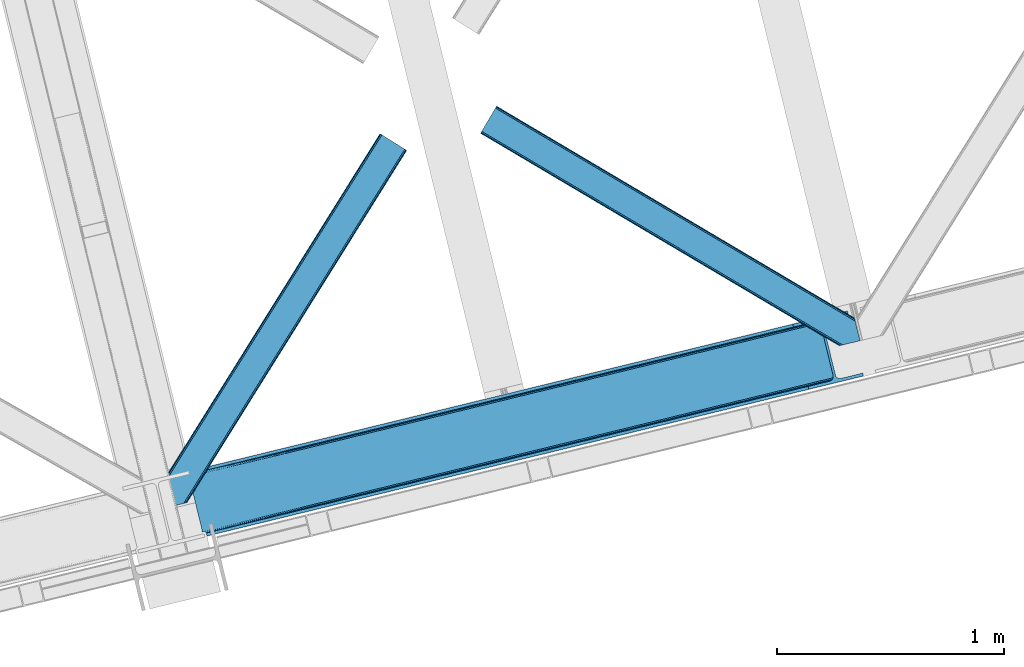
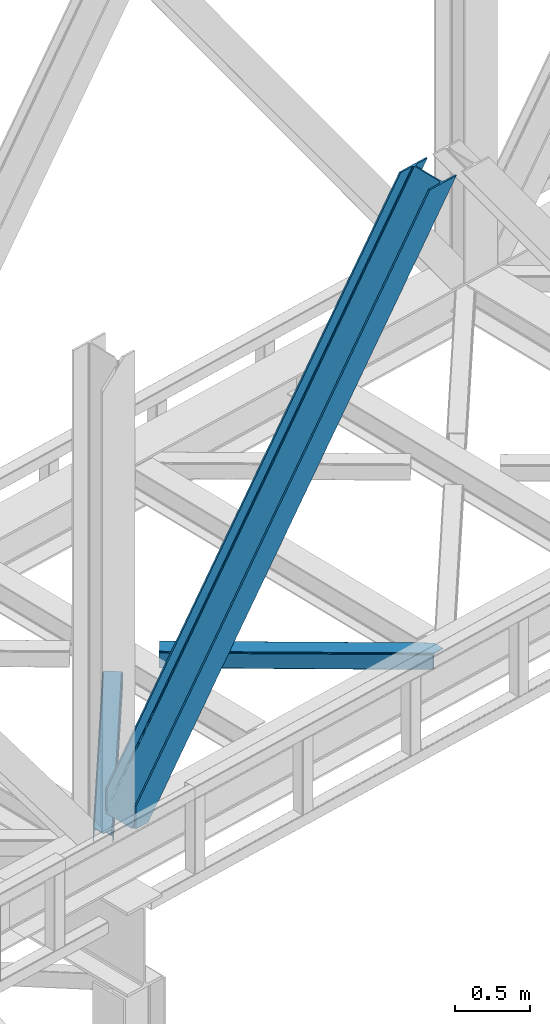
# One storey, part 57 of 93: 3 members.
"""IFC4 building model written with IfcOpenShell, lengths in millimetres."""

from ifc_helpers import new_model, entity, si_unit, converted_unit, derived_unit, direction, frame, origin, place, context, subcontext, project, spatial, triangles, type_object, element, save


model = new_model("IFC4")

# Units and contexts
model_context = context("Model", 3, precision=0.01, world=origin(), true_north=direction((6.12303176911189e-17, 1.0)))
plan_context = context("Plan", 3, precision=0.01, world=origin(), true_north=direction((6.12303176911189e-17, 1.0)))
body_context = subcontext(model_context, "Body", "Model", "MODEL_VIEW")
ifc_project = project(units=[si_unit("LENGTHUNIT", "METRE", prefix="MILLI"), si_unit("AREAUNIT", "SQUARE_METRE"), si_unit("VOLUMEUNIT", "CUBIC_METRE"), converted_unit("PLANEANGLEUNIT", "DEGREE", entity("IfcRatioMeasure", 0.0174532925199433), si_unit("PLANEANGLEUNIT", "RADIAN"), dimensions=[0, 0, 0, 0, 0, 0, 0]), si_unit("MASSUNIT", "GRAM", prefix="KILO"), derived_unit("MASSDENSITYUNIT", [(si_unit("MASSUNIT", "GRAM", prefix="KILO"), 1), (si_unit("LENGTHUNIT", "METRE"), -3)]), derived_unit("MOMENTOFINERTIAUNIT", [(si_unit("LENGTHUNIT", "METRE"), 4)]), si_unit("TIMEUNIT", "SECOND"), si_unit("FREQUENCYUNIT", "HERTZ"), si_unit("THERMODYNAMICTEMPERATUREUNIT", "DEGREE_CELSIUS"), derived_unit("THERMALTRANSMITTANCEUNIT", [(si_unit("MASSUNIT", "GRAM", prefix="KILO"), 1), (si_unit("THERMODYNAMICTEMPERATUREUNIT", "KELVIN"), -1), (si_unit("TIMEUNIT", "SECOND"), -3)]), derived_unit("VOLUMETRICFLOWRATEUNIT", [(si_unit("LENGTHUNIT", "METRE"), 3), (si_unit("TIMEUNIT", "SECOND"), -1)]), derived_unit("MASSFLOWRATEUNIT", [(si_unit("MASSUNIT", "GRAM", prefix="KILO"), 1), (si_unit("TIMEUNIT", "SECOND"), -1)]), derived_unit("ROTATIONALFREQUENCYUNIT", [(si_unit("TIMEUNIT", "SECOND"), -1)]), si_unit("ELECTRICCURRENTUNIT", "AMPERE"), si_unit("ELECTRICVOLTAGEUNIT", "VOLT"), si_unit("POWERUNIT", "WATT"), si_unit("FORCEUNIT", "NEWTON", prefix="KILO"), si_unit("ILLUMINANCEUNIT", "LUX"), si_unit("LUMINOUSFLUXUNIT", "LUMEN"), si_unit("LUMINOUSINTENSITYUNIT", "CANDELA"), derived_unit("USERDEFINED", [(si_unit("MASSUNIT", "GRAM", prefix="KILO"), -1), (si_unit("LENGTHUNIT", "METRE"), -2), (si_unit("TIMEUNIT", "SECOND"), 3), (si_unit("LUMINOUSFLUXUNIT", "LUMEN"), 1)]), derived_unit("LINEARVELOCITYUNIT", [(si_unit("LENGTHUNIT", "METRE"), 1), (si_unit("TIMEUNIT", "SECOND"), -1)]), si_unit("PRESSUREUNIT", "PASCAL"), derived_unit("USERDEFINED", [(si_unit("LENGTHUNIT", "METRE"), -2), (si_unit("MASSUNIT", "GRAM", prefix="KILO"), 1), (si_unit("TIMEUNIT", "SECOND"), -2)]), derived_unit("LINEARFORCEUNIT", [(si_unit("MASSUNIT", "GRAM", prefix="KILO"), 1), (si_unit("LENGTHUNIT", "METRE"), 1), (si_unit("TIMEUNIT", "SECOND"), -2), (si_unit("LENGTHUNIT", "METRE"), -1)]), derived_unit("PLANARFORCEUNIT", [(si_unit("MASSUNIT", "GRAM", prefix="KILO"), 1), (si_unit("LENGTHUNIT", "METRE"), 1), (si_unit("TIMEUNIT", "SECOND"), -2), (si_unit("LENGTHUNIT", "METRE"), -2)])], contexts=[model_context, plan_context])

# Site, building, storey
site_placement = place(None, origin())
site = spatial("IfcSite", under=ifc_project, at=site_placement, CompositionType="ELEMENT")
building_placement = place(site_placement, origin())
building = spatial("IfcBuilding", under=site, at=building_placement, CompositionType="ELEMENT")
storey_placement = place(building_placement, frame((0.0, 0.0, 15900.0)))
storey = spatial("IfcBuildingStorey", under=building, at=storey_placement, CompositionType="ELEMENT", Elevation=15900.0)

# Members
member_type_1 = type_object("IfcMemberType", PredefinedType="BRACE")
member_1_placement = place(storey_placement, frame((-29318.7080932617, 10322.5675964355, 3694.99929199219)))
element("IfcMember", 1, at=member_1_placement, inside=storey, type_object=member_type_1, ObjectType="Steel Vertical Brace", PredefinedType="BRACE", context=body_context, shape_type="Tessellation", body=[
    triangles([(58.549914550782, 26.6251190185558, 0.0), (60.4428222656279, 18.8523376464855, 0.0), (59.105694580081, 19.6708923339847, 0.80925292968459), (58.9708190917991, 18.4930572509766, 1.10690917968532), (64.0867858886741, 19.7406555175785, 8.31577148437282), (64.0867858886741, 19.7406555175785, 0.0), (522.907617187502, 126.716683959961, 658.855133056641), (68.3748962402351, 19.9243652343757, 14.8293273925774), (72.407208251956, 18.4523620605469, 22.4381652832017), (524.584259033203, 133.136059570314, 656.552947998047), (73.9861816406265, 17.2873168945316, 26.4425720214822), (2834.75720214844, 696.264477539064, 3911.00081176758), (2834.77580566406, 703.359393310548, 3911.00081176758), (2385.95203857422, 593.954443359375, 3278.7231262207), (2386.50781860352, 586.999053955078, 3279.53005371094), (2831.44577636719, 689.447451782227, 3911.00081176758), (2384.82885131836, 580.579678344728, 3281.83223876953), (2825.34149780274, 683.943136596679, 3911.00081176758), (2381.1709350586, 575.671838378907, 3285.27854003906), (2817.37686767578, 680.591015625001, 3911.00081176758), (2376.09450073242, 573.024325561524, 3289.34108276367), (514.170941162112, 119.160168457032, 666.36397705078), (519.249700927736, 121.80884399414, 662.301434326171), (77.0999450683594, 12.6201599121105, 50.6410949707024), (76.5674194335952, 13.9003143310547, 38.6743835449197), (75.4046997070327, 15.4258026123043, 33.1630920410134), (524.028479003908, 140.090286254883, 655.74602050781), (990.065148925783, 246.602389526368, 1312.29896850586), (989.509368896484, 253.556616210937, 1311.48971557617), (1455.54603881836, 360.067556762695, 1968.04266357422), (1454.99025878906, 367.021783447266, 1967.23341064453), (1921.02692871094, 473.533886718751, 2623.78635864258), (1920.47114868164, 480.48811340332, 2622.97710571289), (988.388507080079, 240.18185119629, 1314.598828125), (1453.8670715332, 353.648181152344, 1970.34484863281), (1919.34796142578, 467.113348388672, 2626.08854370117), (984.730590820313, 235.274011230469, 1318.04512939453), (1450.21148071289, 348.740341186523, 1973.78882446289), (1915.69004516602, 462.205508422852, 2629.53251953125), (979.651831054689, 232.626498413087, 1322.10767211914), (1445.13272094727, 346.092828369141, 1977.85369262695), (1910.61361083985, 459.55799560547, 2633.59738769531), (77.0999450683594, 12.6201599121105, 182.433050537107), (2723.82443847656, 657.78659362793, 3911.00081176758), (75.569805908206, 15.550213623048, 0.0), (77.381323242189, 11.6585906982418, 0.0), (77.381323242189, 11.6585906982418, 182.495837402341), (68.3748962402351, 19.9243652343757, 0.0), (72.407208251956, 18.4523620605469, 0.0), (2726.9033203125, 645.157131958009, 3911.00081176758), (80.223010253907, 0.0, 182.495837402341), (80.223010253907, 0.0, 0.0), (191.327856445314, 27.0832305908207, 0.0), (2967.5537475586, 703.817504882813, 3911.00081176758), (1399.80990600586, 593.394012451172, 1967.23341064453), (2779.59312744141, 929.730459594726, 3911.00081176758), (2330.77168579102, 820.325509643555, 3278.7231262207), (1865.29079589844, 706.859179687501, 2622.97710571289), (934.329016113283, 479.927682495118, 1311.48971557617), (468.848126220706, 366.462515258789, 655.74602050781), (3.36723632812573, 252.996185302734, 0.0), (2964.47486572266, 716.448129272461, 3911.00081176758), (188.248974609378, 39.7138549804695, 0.0), (2870.92243652344, 693.643707275391, 3911.00081176758), (94.6965454101592, 16.9094329833988, 0.0), (2862.31133422852, 692.954214477539, 3911.00081176758), (86.083117675782, 16.2199401855469, 0.0), (2854.35833129883, 695.031994628907, 3911.00081176758), (78.1324401855491, 18.2977203369137, 0.0), (2848.28195800781, 699.561950683594, 3911.00081176758), (72.0560668945327, 22.8265136718746, 0.0), (2845.00308837891, 705.852264404297, 3911.00081176758), (68.7748718261719, 29.1168273925778, 0.0), (2789.82273559571, 932.224493408203, 3911.00081176758), (13.5945190429702, 255.489056396485, 0.0), (2789.83668823242, 939.318246459961, 3911.00081176758), (13.6107971191414, 262.583972167969, 0.0), (2793.15043945313, 946.135272216798, 3911.00081176758), (16.9245483398445, 269.400997924806, 0.0), (2799.25471801758, 951.639587402344, 3911.00081176758), (23.026501464843, 274.905313110352, 0.0), (2807.21702270508, 954.991708374024, 3911.00081176758), (30.9911315917961, 278.256271362305, 0.0), (2900.7694519043, 977.796130371094, 3911.00081176758), (124.543560791019, 301.060693359375, 0.0), (2897.69057006836, 990.425592041016, 3911.00081176758), (121.464678955079, 313.691317749024, 0.0), (2770.23555908203, 940.550729370118, 3911.00081176758), (2762.2848815918, 942.628509521484, 3911.00081176758), (2657.04014282227, 931.765219116211, 3911.00081176758), (2753.67145385742, 941.939016723632, 3911.00081176758), (2660.1190246582, 919.134594726564, 3911.00081176758), (2776.3142578125, 936.020773315429, 3911.00081176758), (10.3598327636719, 286.608087158203, 182.495837402341), (10.3598327636719, 286.608087158203, 0.0), (13.2015197753899, 274.949496459962, 182.495837402341), (13.3922058105491, 273.966998291016, 182.433050537107), (1381.42730712891, 607.439666748047, 1977.85369262695), (1846.90819702149, 720.905996704101, 2633.59738769531), (2312.38676147461, 834.37116394043, 3289.34108276367), (915.94641723633, 493.97449951172, 1322.10767211914), (13.3922058105491, 273.966998291016, 50.6410949707024), (450.465527343753, 380.508169555664, 666.36397705078), (13.2015197753899, 274.949496459962, 0.0), (13.5108032226563, 272.58568725586, 38.6743835449197), (13.3829040527344, 270.661386108399, 0.0), (13.3829040527344, 270.661386108399, 32.1678039550752), (12.4783081054702, 268.183630371093, 26.1867736816384), (11.9132263183601, 266.62907409668, 22.4381652832017), (11.9132263183601, 266.62907409668, 0.0), (9.00875244140843, 263.467639160157, 14.8293273925774), (9.00875244140843, 263.467639160157, 0.0), (5.11829223632958, 261.6572845459, 8.31577148437282), (5.11829223632958, 261.6572845459, 0.0), (1.47432861328343, 260.768966674805, 0.0), (461.697399902347, 377.819961547852, 658.855133056641), (456.193084716797, 380.494216918945, 662.301434326171), (466.141314697266, 372.892355346679, 656.552947998047), (0.662750244140625, 259.427188110352, 0.80925292968459), (0.0, 260.409686279298, 1.10690917968532), (2318.11431884766, 834.357211303712, 3285.27854003906), (2323.62095947266, 831.682955932618, 3281.83223876953), (2328.06487426758, 826.755349731446, 3279.53005371094), (921.671649169923, 493.959384155274, 1318.04512939453), (1387.1525390625, 607.425714111328, 1973.78882446289), (1852.63342895508, 720.890881347657, 2629.53251953125), (927.178289794923, 491.28512878418, 1314.598828125), (1392.6591796875, 604.751458740235, 1970.34484863281), (1858.14006958008, 718.216625976564, 2626.08854370117), (931.622204589847, 486.358685302735, 1312.29896850586), (1397.10309448242, 599.823852539063, 1968.04266357422), (1862.583984375, 713.290182495117, 2623.78635864258)], [[1, 2, 3], [4, 3, 2], [5, 4, 6], [2, 6, 4], [7, 8, 9], [10, 3, 8], [8, 7, 10], [9, 11, 7], [3, 4, 5], [5, 8, 3], [12, 13, 14], [14, 15, 12], [16, 12, 15], [15, 17, 16], [18, 16, 17], [17, 19, 18], [20, 18, 19], [19, 21, 20], [22, 23, 24], [25, 24, 23], [25, 7, 26], [25, 23, 7], [11, 26, 7], [10, 27, 1], [1, 3, 10], [28, 29, 27], [27, 10, 28], [30, 31, 28], [29, 28, 31], [32, 33, 31], [31, 30, 32], [15, 14, 33], [33, 32, 15], [34, 28, 10], [10, 7, 34], [35, 30, 28], [28, 34, 35], [36, 32, 35], [30, 35, 32], [17, 15, 36], [32, 36, 15], [37, 34, 23], [7, 23, 34], [38, 35, 37], [34, 37, 35], [39, 36, 38], [35, 38, 36], [19, 17, 36], [36, 39, 19], [40, 37, 22], [23, 22, 37], [41, 38, 40], [37, 40, 38], [42, 39, 41], [38, 41, 39], [21, 19, 42], [39, 42, 19], [41, 43, 44], [44, 21, 42], [21, 44, 20], [42, 41, 44], [43, 41, 40], [40, 22, 43], [24, 43, 22], [45, 11, 9], [45, 26, 11], [46, 25, 26], [46, 47, 24], [43, 24, 47], [24, 25, 46], [26, 45, 46], [48, 8, 5], [5, 6, 48], [49, 9, 8], [8, 48, 49], [9, 49, 45], [47, 44, 43], [50, 47, 51], [47, 50, 44], [52, 51, 46], [47, 46, 51], [50, 53, 54], [53, 50, 51], [52, 53, 51], [33, 55, 31], [13, 56, 57], [58, 14, 57], [55, 33, 58], [57, 14, 13], [58, 33, 14], [31, 59, 29], [59, 60, 27], [59, 31, 55], [61, 1, 60], [59, 27, 29], [60, 1, 27], [62, 54, 53], [53, 63, 62], [64, 62, 63], [63, 65, 64], [66, 64, 65], [65, 67, 66], [68, 66, 67], [67, 69, 68], [70, 68, 69], [69, 71, 70], [72, 70, 71], [71, 73, 72], [74, 72, 75], [73, 75, 72], [76, 74, 77], [75, 77, 74], [78, 76, 79], [77, 79, 76], [80, 78, 81], [79, 81, 78], [82, 80, 83], [81, 83, 80], [84, 82, 85], [83, 85, 82], [86, 84, 85], [85, 87, 86], [56, 13, 74], [16, 18, 66], [20, 50, 54], [44, 50, 20], [18, 20, 64], [13, 12, 70], [12, 16, 68], [88, 80, 89], [90, 91, 86], [91, 89, 82], [90, 92, 91], [88, 93, 78], [93, 56, 76], [74, 13, 72], [64, 66, 18], [70, 12, 68], [66, 68, 16], [70, 72, 13], [54, 64, 20], [54, 62, 64], [82, 89, 80], [78, 93, 76], [74, 76, 56], [78, 80, 88], [82, 86, 91], [86, 82, 84], [90, 87, 94], [90, 86, 87], [87, 95, 94], [96, 90, 94], [92, 96, 97], [96, 92, 90], [92, 97, 98], [98, 99, 92], [99, 100, 92], [91, 92, 100], [101, 98, 97], [97, 102, 103], [103, 101, 97], [104, 96, 94], [94, 95, 104], [104, 105, 102], [104, 106, 107], [107, 105, 104], [96, 104, 102], [102, 97, 96], [108, 106, 109], [108, 107, 106], [110, 109, 106], [109, 110, 111], [112, 111, 110], [111, 112, 113], [114, 113, 112], [75, 73, 61], [114, 75, 61], [114, 112, 75], [114, 61, 115], [79, 77, 110], [77, 75, 112], [106, 79, 110], [110, 77, 112], [73, 1, 61], [6, 73, 48], [1, 6, 2], [1, 73, 6], [48, 71, 49], [49, 71, 69], [73, 71, 48], [45, 49, 69], [104, 81, 79], [79, 106, 104], [95, 81, 104], [83, 95, 87], [87, 85, 83], [83, 81, 95], [45, 69, 46], [52, 67, 65], [46, 69, 67], [52, 46, 67], [65, 53, 52], [53, 65, 63], [116, 117, 105], [105, 107, 116], [118, 111, 113], [113, 119, 118], [118, 116, 108], [108, 109, 118], [109, 111, 118], [113, 120, 119], [107, 108, 116], [117, 103, 102], [102, 105, 117], [89, 91, 121], [100, 121, 91], [88, 89, 122], [121, 122, 89], [93, 88, 123], [122, 123, 88], [56, 93, 57], [123, 57, 93], [124, 101, 103], [103, 117, 124], [125, 98, 101], [101, 124, 125], [126, 99, 98], [98, 125, 126], [121, 100, 126], [99, 126, 100], [127, 124, 116], [117, 116, 124], [128, 125, 124], [124, 127, 128], [129, 126, 128], [125, 128, 126], [122, 121, 129], [126, 129, 121], [130, 127, 118], [116, 118, 127], [131, 128, 130], [127, 130, 128], [132, 129, 128], [128, 131, 132], [123, 122, 129], [129, 132, 123], [60, 118, 61], [119, 61, 118], [59, 130, 60], [118, 60, 130], [55, 131, 130], [130, 59, 55], [58, 132, 55], [131, 55, 132], [57, 123, 58], [132, 58, 123], [120, 113, 114], [114, 115, 120], [115, 61, 119], [119, 120, 115]]),
])
member_type_2 = type_object("IfcMemberType", PredefinedType="BRACE")
member_2_placement = place(storey_placement, frame((-29442.5330932617, 10446.8344299316, 3510.00011901855)))
element("IfcMember", 2, at=member_2_placement, inside=storey, type_object=member_type_2, ObjectType="Steel Horizontal Brace", PredefinedType="BRACE", context=body_context, shape_type="Tessellation", body=[
    triangles([(116.813800048829, 229.38483581543, 5.52059326172093), (80.4834594726563, 220.529562377929, 5.52059326172093), (108.163165283204, 264.867553710938, 5.52059326172093), (117.183544921878, 229.4755279541, 5.44385375976708), (117.499804687501, 229.552267456054, 5.22758789062573), (108.467797851565, 265.047775268555, 5.35316162109666), (108.779406738282, 265.232647705077, 5.18107910156323), (109.021252441409, 265.045449829102, 4.88574829101708), (108.879400634767, 265.291946411133, 5.12526855468968), (117.709094238282, 229.603427124022, 4.90318908691552), (109.242169189456, 264.669891357422, 4.52065429687718), (117.783508300781, 229.622030639648, 4.52065429687718), (113.127978515626, 248.727841186523, 0.0), (110.909509277346, 257.823797607422, 1.33247680664135), (117.783508300781, 229.622030639648, 0.0), (973.808001708985, 1640.09989013672, 1.33247680664135), (968.992016601565, 1643.10668334961, 5.12526855468968), (965.773608398438, 1645.11586303711, 10.8028289794929), (75.7418884277358, 219.37265625, 10.8028289794929), (979.48905029297, 1636.5535949707, 0.0), (964.645770263673, 1645.82047119141, 17.5000946044929), (73.8885131835959, 218.921520996093, 17.5000946044929), (127.499194335938, 231.98932800293, 0.0), (1068.55803222656, 1580.95117492676, 0.0), (155.288195800782, 117.985821533202, 0.0), (1074.23908081055, 1577.40487976074, 1.33247680664135), (157.506665039065, 108.891027832031, 1.33247680664135), (1079.05506591797, 1574.39808654785, 5.12526855468968), (159.385620117188, 101.179870605469, 5.12526855468968), (1082.2734741211, 1572.39006958008, 10.8028289794929), (160.641357421875, 96.0278594970696, 10.8028289794929), (1083.40363769532, 1571.68429870605, 17.5000946044929), (161.083190917969, 94.2186676025394, 17.5000946044929), (127.499194335938, 231.98932800293, 6.99957275390625), (107.953875732423, 227.225665283202, 6.99957275390625), (98.6428161621116, 224.956036376952, 8.3320495605476), (86.1482299804702, 221.909710693359, 18.0686645507813), (90.7502746582031, 223.031735229491, 12.1260040283232), (84.264624023439, 221.450436401366, 20.4999114990242), (73.8885131835959, 218.921520996093, 20.4999114990242), (985.425897216799, 1632.84684448242, 6.99957275390625), (1062.62118530274, 1584.65792541504, 6.99957275390625), (152.972058105472, 127.492218017578, 6.99957275390625), (157.067156982423, 110.68742980957, 12.1260040283232), (155.188201904297, 118.397424316407, 8.3320495605476), (158.222900390625, 105.947021484375, 17.9802978515654), (158.52288208008, 104.716864013672, 19.4999725341804), (161.083190917969, 94.2186676025394, 19.4999725341804), (157.871759033205, 103.169284057616, 20.4999114990242), (160.341375732423, 93.0338562011711, 20.4999114990242), (116.220812988282, 22.3544494628895, 20.4999114990242), (105.842376708984, 19.8255340576161, 20.4999114990242), (1083.40363769532, 1571.68429870605, 122.500662231447), (116.220812988282, 22.3544494628895, 122.500662231447), (1076.33662719727, 1576.09682006836, 17.8035644531265), (1073.11821899414, 1578.10483703613, 12.1260040283232), (1077.46446533203, 1575.39104919434, 24.4996673583992), (106.486523437503, 19.982501220702, 24.4996673583992), (1068.30223388672, 1581.11163024902, 8.3320495605476), (1082.2734741211, 1572.39006958008, 129.197927856447), (114.367437744142, 21.9033142089847, 129.197927856447), (1079.05506591797, 1574.39808654785, 134.874325561526), (109.093341064454, 20.6173461914059, 134.874325561526), (1074.23908081055, 1577.40487976074, 138.667117309571), (101.198474121094, 18.6930450439449, 138.667117309571), (1068.55803222656, 1580.95117492676, 139.999594116212), (91.8874145507834, 16.4234161376953, 139.999594116212), (1077.46446533203, 1575.39104919434, 115.501089477541), (106.486523437503, 19.982501220702, 115.501089477541), (1062.62118530274, 1584.65792541504, 133.000021362306), (1068.30223388672, 1581.11163024902, 131.667544555665), (91.4641845703154, 16.3199340820302, 131.667544555665), (82.1554504394553, 14.0503051757805, 133.000021362306), (1073.11821899414, 1578.10483703613, 127.87475280762), (99.3613769531257, 18.2453979492184, 127.87475280762), (1076.33662719727, 1576.09682006836, 122.196029663086), (104.635473632814, 19.5302032470699, 122.196029663086), (24.5101318359375, 0.0, 139.999594116212), (24.5101318359375, 0.0, 133.000021362306), (2.46961669922166, 90.4212249755856, 20.4999114990242), (0.0, 100.556652832031, 20.4999114990242), (964.645770263673, 1645.82047119141, 122.500662231447), (0.0, 100.556652832031, 122.500662231447), (5.79266967773583, 76.7894989013676, 139.999594116212), (979.48905029297, 1636.5535949707, 139.999594116212), (973.808001708985, 1640.09989013672, 138.667117309571), (3.57652587890698, 85.8854553222645, 138.667117309571), (968.992016601565, 1643.10668334961, 134.874325561526), (1.69524536133031, 93.5954498291012, 134.874325561526), (965.773608398438, 1645.11586303711, 129.197927856447), (0.439508056642808, 98.7474609375004, 129.197927856447), (970.582617187501, 1642.11372070312, 24.4996673583992), (2.31613769531396, 91.0502563476566, 24.4996673583992), (971.710455322267, 1641.4079498291, 17.8035644531265), (979.744848632814, 1636.39313964844, 8.3320495605476), (974.928863525394, 1639.39993286133, 12.1260040283232), (974.928863525394, 1639.39993286133, 127.87475280762), (985.425897216799, 1632.84684448242, 133.000021362306), (979.744848632814, 1636.39313964844, 131.667544555665), (970.582617187501, 1642.11372070312, 115.501089477541), (971.710455322267, 1641.4079498291, 122.196029663086), (4.01370849609521, 84.0890533447255, 127.87475280762), (2.75797119140771, 89.2410644531246, 122.196029663086), (8.10880737304979, 67.2831024169918, 133.000021362306), (5.89266357422093, 76.3790588378906, 131.667544555665), (2.31613769531396, 91.0502563476566, 115.501089477541)], [[1, 2, 3], [4, 1, 3], [5, 4, 6], [5, 7, 8], [7, 9, 8], [10, 8, 11], [11, 12, 10], [8, 10, 5], [6, 7, 5], [3, 6, 4], [11, 13, 12], [13, 11, 14], [15, 12, 13], [16, 14, 11], [11, 17, 16], [11, 9, 17], [18, 17, 9], [18, 3, 19], [2, 19, 3], [16, 20, 14], [13, 14, 20], [21, 18, 19], [19, 22, 21], [23, 24, 25], [24, 13, 20], [13, 24, 23], [23, 15, 13], [24, 26, 25], [27, 25, 26], [26, 28, 27], [29, 27, 28], [28, 30, 29], [31, 29, 30], [30, 32, 31], [33, 31, 32], [15, 23, 10], [10, 34, 1], [34, 10, 23], [35, 1, 34], [36, 2, 35], [35, 2, 1], [2, 37, 19], [38, 37, 2], [2, 36, 38], [37, 39, 19], [39, 22, 19], [39, 40, 22], [34, 41, 35], [42, 34, 43], [34, 42, 41], [44, 27, 29], [34, 23, 43], [23, 25, 43], [27, 45, 25], [44, 45, 27], [45, 43, 25], [46, 44, 29], [31, 46, 29], [47, 31, 33], [31, 47, 46], [33, 48, 47], [49, 50, 51], [51, 52, 49], [53, 48, 32], [48, 53, 54], [33, 32, 48], [54, 50, 48], [54, 51, 50], [55, 56, 44], [57, 55, 46], [46, 47, 57], [47, 49, 57], [57, 49, 58], [52, 58, 49], [44, 46, 55], [56, 59, 45], [45, 44, 56], [59, 42, 43], [43, 45, 59], [53, 60, 54], [61, 54, 60], [60, 62, 61], [63, 61, 62], [62, 64, 63], [65, 63, 64], [64, 66, 65], [67, 65, 66], [68, 57, 69], [58, 69, 57], [70, 71, 72], [72, 73, 70], [71, 74, 75], [75, 72, 71], [74, 76, 77], [77, 75, 74], [76, 68, 69], [69, 77, 76], [77, 61, 63], [73, 67, 78], [78, 79, 73], [73, 72, 67], [72, 65, 67], [75, 65, 72], [63, 65, 75], [77, 54, 61], [69, 54, 77], [63, 75, 77], [51, 58, 52], [69, 51, 54], [58, 51, 69], [40, 39, 80], [80, 81, 40], [40, 21, 22], [82, 40, 83], [40, 82, 21], [40, 81, 83], [66, 84, 67], [66, 85, 84], [84, 78, 67], [85, 86, 87], [87, 84, 85], [86, 88, 89], [89, 87, 86], [88, 90, 91], [91, 89, 88], [90, 82, 83], [83, 91, 90], [92, 93, 39], [39, 94, 92], [39, 37, 94], [93, 80, 39], [94, 37, 38], [41, 95, 35], [36, 35, 95], [95, 96, 36], [38, 36, 96], [38, 96, 94], [30, 56, 55], [57, 53, 32], [30, 55, 32], [30, 28, 56], [55, 57, 32], [56, 28, 26], [42, 24, 20], [24, 59, 26], [59, 24, 42], [59, 56, 26], [60, 74, 62], [68, 53, 57], [53, 76, 60], [76, 53, 68], [60, 76, 74], [66, 70, 85], [64, 62, 74], [74, 71, 64], [71, 70, 66], [66, 64, 71], [96, 16, 17], [20, 41, 42], [20, 95, 41], [95, 20, 16], [96, 95, 16], [92, 21, 82], [18, 94, 96], [17, 18, 96], [94, 18, 21], [92, 94, 21], [86, 97, 88], [85, 70, 98], [98, 99, 85], [99, 97, 86], [86, 85, 99], [90, 88, 97], [82, 100, 92], [101, 82, 90], [82, 101, 100], [101, 90, 97], [102, 89, 103], [79, 78, 104], [78, 84, 104], [87, 105, 84], [102, 105, 87], [105, 104, 84], [102, 87, 89], [83, 81, 106], [91, 103, 89], [106, 103, 83], [103, 91, 83], [81, 93, 106], [81, 80, 93], [70, 104, 98], [104, 70, 73], [79, 104, 73], [92, 100, 93], [106, 93, 100], [100, 101, 106], [103, 106, 101], [101, 97, 103], [102, 103, 97], [97, 99, 102], [105, 102, 99], [99, 98, 105], [104, 105, 98]]),
])
member_type_3 = type_object("IfcMemberType", PredefinedType="BRACE")
member_3_placement = place(storey_placement, frame((-28035.698034668, 11159.1828094482, 3510.00011901855)))
element("IfcMember", 3, at=member_3_placement, inside=storey, type_object=member_type_3, ObjectType="Steel Horizontal Brace", PredefinedType="BRACE", context=body_context, shape_type="Tessellation", body=[
    triangles([(1465.49891967774, 208.966314697265, 0.0), (1500.25958862305, 66.3657165527347, 0.0), (8.91573486328343, 949.276940917969, 0.0), (62.405493164064, 1039.62956542969, 0.0), (0.679028320311772, 935.364999389649, 10.8028289794929), (1580.23377685547, 0.541827392578853, 10.8679412841811), (1578.00833129883, 0.0, 17.5000946044929), (1506.61734008789, 44.5019348144524, 9.52034912109593), (2.6114685058601, 938.628753662109, 5.12526855468968), (1504.3546875, 49.5597656249993, 5.12526855468968), (1505.23137817383, 45.9657989501957, 8.52041015625218), (1506.28247680664, 44.8554016113285, 9.27850341796875), (1505.92435913086, 45.2344482421868, 9.02037963867406), (1505.56624145508, 45.6123321533196, 8.76225585937573), (1580.68491210938, 0.65228576660229, 9.52034912109593), (1502.47573242188, 57.2709228515632, 1.33247680664135), (5.50431518554615, 943.514501953125, 1.33247680664135), (0.0, 934.218557739257, 17.5000946044929), (1578.00833129883, 0.0, 122.500662231447), (0.0, 934.218557739257, 122.500662231447), (1593.02834472656, 3.66140441894458, 138.667117309571), (1602.33940429688, 5.93103332519604, 139.999594116212), (8.91573486328343, 949.276940917969, 139.999594116212), (5.50431518554615, 943.514501953125, 138.667117309571), (1585.13347778321, 1.73710327148365, 134.874325561526), (2.6114685058601, 938.628753662109, 134.874325561526), (1579.85938110352, 0.451135253906614, 129.197927856447), (0.679028320311772, 935.364999389649, 129.197927856447), (1500.30377197266, 66.1831695556648, 8.52041015625218), (1500.66188964844, 65.0402160644535, 8.90294494629052), (1501.15255737305, 64.3216552734375, 9.10758361816625), (1501.64787597656, 63.5914672851559, 9.31571044922021), (1502.13854370117, 62.8729064941399, 9.52034912109593), (1599.49306640625, 5.23688964843677, 9.52034912109593), (9.07153930664208, 949.538552856446, 8.3320495605476), (1500.15029296875, 66.8075500488285, 8.42274169922166), (6.1786926269524, 944.65280456543, 12.1260040283232), (1594.86776733398, 4.11021423339844, 12.1260040283232), (1497.94112548828, 75.8721130371086, 6.99957275390625), (12.4829589843757, 955.300991821288, 6.99957275390625), (1589.5936706543, 2.82424621581958, 17.8035644531265), (4.24625244140771, 941.387887573243, 17.8035644531265), (1587.74029541016, 2.3719482421875, 24.4996673583992), (3.56489868164135, 940.241445922851, 24.4996673583992), (1467.81505737305, 199.458755493164, 6.99957275390625), (58.8405944824226, 1033.60667724609, 6.99957275390625), (1460.52713012695, 229.365069580079, 8.52041015625218), (1465.45473632813, 209.14769897461, 8.52041015625218), (1461.40149536133, 225.771102905273, 5.12526855468968), (1465.60588989258, 208.524481201172, 8.42274169922166), (1463.28045043946, 218.061108398437, 1.33247680664135), (1587.74029541016, 2.3719482421875, 115.501089477541), (3.56489868164135, 940.241445922851, 115.501089477541), (1589.5936706543, 2.82424621581958, 122.196029663086), (4.24625244140771, 941.387887573243, 122.196029663086), (1594.86776733398, 4.11021423339844, 127.87475280762), (6.1786926269524, 944.65280456543, 127.87475280762), (1602.76263427734, 6.03451538085938, 131.667544555665), (9.07153930664208, 949.538552856446, 131.667544555665), (1612.07369384766, 8.30414428710901, 133.000021362306), (12.4829589843757, 955.300991821288, 133.000021362306), (1669.50739746094, 22.3044525146488, 139.999594116212), (1669.50739746094, 22.3044525146488, 133.000021362306), (1650.74110107422, 99.2974273681648, 139.999594116212), (62.405493164064, 1039.62956542969, 139.999594116212), (1653.05723876953, 89.7910308837891, 133.000021362306), (58.8405944824226, 1033.60667724609, 133.000021362306), (1645.38793945313, 121.255389404298, 129.197927856447), (1644.94610595703, 123.064581298828, 122.500662231447), (70.642199707032, 1053.54266967773, 129.197927856447), (71.3235534667983, 1054.68911132813, 122.500662231447), (1646.64367675781, 116.103378295898, 134.874325561526), (68.7120849609382, 1050.27891540527, 134.874325561526), (1648.52263183594, 108.393383789062, 138.667117309571), (65.8192382812522, 1045.39316711426, 138.667117309571), (1644.94610595703, 123.064581298828, 17.5000946044929), (71.3235534667983, 1054.68911132813, 17.5000946044929), (70.642199707032, 1053.54266967773, 10.8028289794929), (65.1448608398459, 1044.25486450195, 12.1260040283232), (67.0773010253906, 1047.51978149414, 17.8035644531265), (67.7563293457024, 1048.6650604248, 24.4996673583992), (68.7120849609382, 1050.27891540527, 5.12526855468968), (65.8192382812522, 1045.39316711426, 1.33247680664135), (62.2520141601563, 1039.36911621094, 8.3320495605476), (65.1448608398459, 1044.25486450195, 127.87475280762), (67.7563293457024, 1048.6650604248, 115.501089477541), (67.0773010253906, 1047.51978149414, 122.196029663086), (62.2520141601563, 1039.36911621094, 131.667544555665), (1647.2645690918, 113.558184814454, 24.4996673583992), (1647.2645690918, 113.558184814454, 115.501089477541), (1650.8410949707, 98.8869873046879, 131.667544555665), (1648.96213989258, 106.596981811523, 127.87475280762), (1647.70640258789, 111.748992919922, 122.196029663086), (1647.79476928711, 111.385061645507, 17.8686767578147), (1647.90173950195, 110.943228149414, 16.5199218750022), (1644.95540771485, 123.027374267578, 16.5199218750022), (1638.66741943359, 124.97144165039, 10.8702667236357), (1460.74572143555, 229.701095581055, 9.22734375000073), (1460.63642578125, 229.532501220703, 8.87387695312646), (1461.54567260742, 229.405764770509, 9.52034912109593), (1637.16518554688, 125.43536682129, 9.52034912109593), (1643.67409057617, 109.725860595703, 12.1260040283232), (1466.02446899414, 211.034793090821, 9.52034912109593), (1641.64398193359, 107.063232421875, 9.52034912109593)], [[1, 2, 3], [3, 4, 1], [5, 6, 7], [6, 5, 8], [5, 9, 10], [10, 11, 5], [12, 5, 13], [12, 8, 5], [5, 14, 13], [5, 11, 14], [8, 15, 6], [16, 10, 9], [9, 17, 16], [2, 16, 17], [17, 3, 2], [7, 18, 5], [7, 19, 20], [20, 18, 7], [21, 22, 23], [23, 24, 21], [25, 21, 24], [24, 26, 25], [27, 25, 26], [26, 28, 27], [19, 27, 28], [28, 20, 19], [11, 29, 30], [14, 30, 31], [13, 31, 32], [12, 32, 33], [33, 8, 12], [32, 12, 13], [31, 13, 14], [30, 14, 11], [34, 15, 33], [8, 33, 15], [35, 30, 29], [32, 35, 33], [35, 32, 31], [30, 35, 31], [29, 36, 35], [37, 38, 33], [33, 35, 37], [38, 34, 33], [35, 36, 39], [39, 40, 35], [41, 38, 37], [37, 42, 41], [43, 41, 42], [42, 44, 43], [39, 45, 40], [46, 40, 45], [1, 45, 39], [47, 48, 49], [48, 50, 1], [45, 1, 50], [48, 51, 49], [48, 1, 51], [2, 1, 39], [2, 39, 36], [29, 2, 36], [11, 10, 29], [29, 16, 2], [29, 10, 16], [52, 43, 44], [44, 53, 52], [54, 52, 55], [53, 55, 52], [56, 54, 57], [55, 57, 54], [58, 56, 59], [57, 59, 56], [60, 58, 61], [59, 61, 58], [56, 58, 21], [25, 56, 21], [25, 27, 54], [56, 25, 54], [54, 27, 19], [58, 22, 21], [62, 60, 63], [62, 22, 60], [58, 60, 22], [54, 19, 52], [43, 7, 41], [19, 43, 52], [7, 6, 41], [19, 7, 43], [15, 41, 6], [38, 41, 15], [34, 38, 15], [22, 64, 23], [22, 62, 64], [65, 23, 64], [66, 60, 61], [60, 66, 63], [61, 67, 66], [68, 69, 70], [71, 70, 69], [72, 68, 73], [70, 73, 68], [74, 72, 75], [73, 75, 72], [64, 74, 65], [75, 65, 74], [69, 76, 77], [77, 71, 69], [78, 79, 80], [81, 71, 77], [78, 80, 77], [78, 82, 79], [80, 81, 77], [79, 82, 83], [46, 4, 3], [4, 84, 83], [84, 4, 46], [84, 79, 83], [70, 85, 73], [86, 71, 81], [71, 87, 70], [87, 71, 86], [70, 87, 85], [65, 67, 23], [75, 73, 85], [85, 88, 75], [88, 67, 65], [65, 75, 88], [37, 17, 9], [3, 40, 46], [3, 35, 40], [35, 3, 17], [37, 35, 17], [44, 18, 20], [5, 42, 37], [9, 5, 37], [42, 5, 18], [44, 42, 18], [24, 57, 26], [23, 67, 61], [61, 59, 23], [59, 57, 24], [24, 23, 59], [28, 26, 57], [20, 53, 44], [55, 20, 28], [20, 55, 53], [55, 28, 57], [89, 90, 81], [86, 81, 90], [91, 66, 67], [67, 88, 91], [92, 91, 88], [88, 85, 92], [93, 92, 85], [85, 87, 93], [90, 93, 87], [87, 86, 90], [92, 72, 74], [66, 91, 64], [91, 92, 74], [94, 95, 96], [63, 66, 62], [64, 62, 66], [91, 74, 64], [94, 76, 89], [69, 90, 89], [89, 76, 69], [94, 96, 76], [69, 93, 90], [93, 72, 92], [72, 93, 68], [69, 68, 93], [77, 76, 97], [76, 96, 97], [98, 99, 82], [47, 82, 99], [47, 49, 82], [78, 97, 100], [100, 82, 78], [100, 98, 82], [97, 101, 100], [51, 1, 4], [4, 83, 51], [49, 51, 83], [83, 82, 49], [97, 78, 77], [80, 79, 102], [102, 95, 80], [80, 94, 89], [46, 45, 50], [103, 102, 79], [103, 104, 102], [50, 79, 84], [50, 103, 79], [50, 84, 46], [89, 81, 80], [95, 94, 80], [96, 102, 97], [102, 96, 95], [102, 101, 97], [102, 104, 101], [101, 104, 103], [103, 100, 101]]),
])

save(model, "model.ifc")
